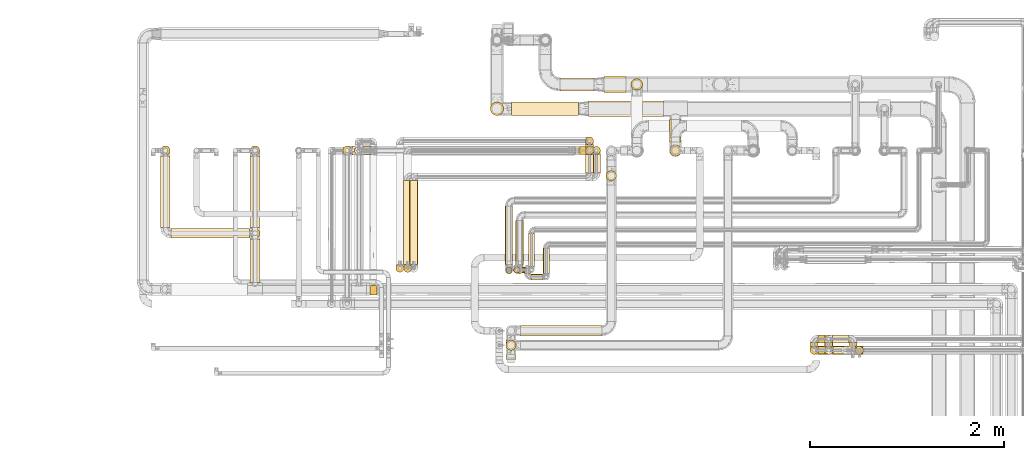
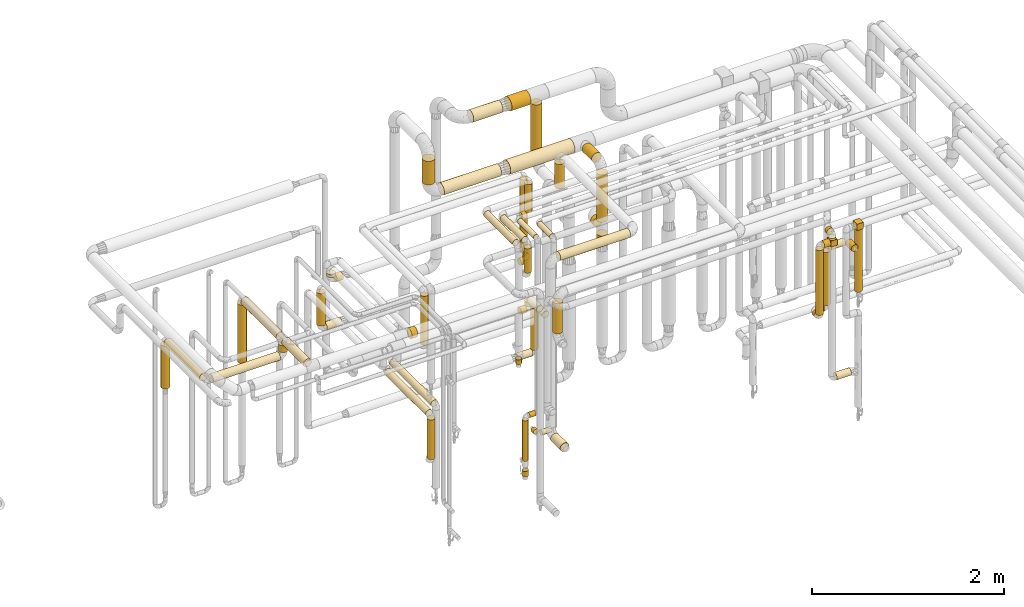
# One storey, part 17 of 827: 65 coverings.
"""IFC2X3 building model written with IfcOpenShell, lengths in millimetres."""

from ifc_helpers import new_model, entity, si_unit, converted_unit, derived_unit, direction, frame, frame_2d, origin, origin_2d_with_axis, place, context, subcontext, project, spatial, polyline, circle_curve, parameter, trimmed, segment, composite_curve, rectangle, circle, outline, extrude, element, save


model = new_model("IFC2X3")

# Units and contexts
model_context = context("Model", 3, precision=0.01, world=origin(), true_north=direction((6.12303176911189e-17, 1.0)))
body_context = subcontext(model_context, "Body", "Model", "MODEL_VIEW")
ifc_project = project(units=[si_unit("LENGTHUNIT", "METRE", prefix="MILLI"), si_unit("AREAUNIT", "SQUARE_METRE"), si_unit("VOLUMEUNIT", "CUBIC_METRE"), converted_unit("PLANEANGLEUNIT", "DEGREE", entity("IfcRatioMeasure", 0.0174532925199433), si_unit("PLANEANGLEUNIT", "RADIAN"), dimensions=[0, 0, 0, 0, 0, 0, 0]), si_unit("MASSUNIT", "GRAM", prefix="KILO"), derived_unit("MASSDENSITYUNIT", [(si_unit("MASSUNIT", "GRAM", prefix="KILO"), 1), (si_unit("LENGTHUNIT", "METRE"), -3)]), derived_unit("MOMENTOFINERTIAUNIT", [(si_unit("LENGTHUNIT", "METRE"), 4)]), si_unit("TIMEUNIT", "SECOND"), si_unit("FREQUENCYUNIT", "HERTZ"), si_unit("THERMODYNAMICTEMPERATUREUNIT", "DEGREE_CELSIUS"), derived_unit("THERMALTRANSMITTANCEUNIT", [(si_unit("MASSUNIT", "GRAM", prefix="KILO"), 1), (si_unit("THERMODYNAMICTEMPERATUREUNIT", "KELVIN"), -1), (si_unit("TIMEUNIT", "SECOND"), -3)]), derived_unit("VOLUMETRICFLOWRATEUNIT", [(si_unit("LENGTHUNIT", "METRE"), 3), (si_unit("TIMEUNIT", "SECOND"), -1)]), derived_unit("MASSFLOWRATEUNIT", [(si_unit("MASSUNIT", "GRAM", prefix="KILO"), 1), (si_unit("TIMEUNIT", "SECOND"), -1)]), derived_unit("ROTATIONALFREQUENCYUNIT", [(si_unit("TIMEUNIT", "SECOND"), -1)]), si_unit("ELECTRICCURRENTUNIT", "AMPERE"), si_unit("ELECTRICVOLTAGEUNIT", "VOLT"), si_unit("POWERUNIT", "WATT"), si_unit("FORCEUNIT", "NEWTON", prefix="KILO"), si_unit("ILLUMINANCEUNIT", "LUX"), si_unit("LUMINOUSFLUXUNIT", "LUMEN"), si_unit("LUMINOUSINTENSITYUNIT", "CANDELA"), derived_unit("USERDEFINED", [(si_unit("MASSUNIT", "GRAM", prefix="KILO"), -1), (si_unit("LENGTHUNIT", "METRE"), -2), (si_unit("TIMEUNIT", "SECOND"), 3), (si_unit("LUMINOUSFLUXUNIT", "LUMEN"), 1)]), derived_unit("LINEARVELOCITYUNIT", [(si_unit("LENGTHUNIT", "METRE"), 1), (si_unit("TIMEUNIT", "SECOND"), -1)]), si_unit("PRESSUREUNIT", "PASCAL"), derived_unit("USERDEFINED", [(si_unit("LENGTHUNIT", "METRE"), -2), (si_unit("MASSUNIT", "GRAM", prefix="KILO"), 1), (si_unit("TIMEUNIT", "SECOND"), -2)]), derived_unit("LINEARFORCEUNIT", [(si_unit("MASSUNIT", "GRAM", prefix="KILO"), 1), (si_unit("LENGTHUNIT", "METRE"), 1), (si_unit("TIMEUNIT", "SECOND"), -2), (si_unit("LENGTHUNIT", "METRE"), -1)]), derived_unit("PLANARFORCEUNIT", [(si_unit("MASSUNIT", "GRAM", prefix="KILO"), 1), (si_unit("LENGTHUNIT", "METRE"), 1), (si_unit("TIMEUNIT", "SECOND"), -2), (si_unit("LENGTHUNIT", "METRE"), -2)])], contexts=[model_context])

# Site, building, storey
site_placement = place(None, origin())
site = spatial("IfcSite", under=ifc_project, at=site_placement, CompositionType="ELEMENT")
building_placement = place(site_placement, origin())
building = spatial("IfcBuilding", under=site, at=building_placement, CompositionType="ELEMENT")
storey_placement = place(building_placement, frame((0.0, 0.0, 28200.0)))
storey = spatial("IfcBuildingStorey", under=building, at=storey_placement, Name="08", CompositionType="ELEMENT", Elevation=28200.0)

# Coverings
covering_1_placement = place(storey_placement, frame((53070.46, 17449.4, 1898.17)))
element("IfcCovering", 1, at=covering_1_placement, inside=storey, Name=":ADSK_", ObjectType=":ADSK_", PredefinedType="INSULATION", context=body_context, shape_type="SweptSolid", body=[
    extrude(circle(Radius=49.0, at=origin_2d_with_axis()), frame((50.6, 50.6, 0.0), z_axis=(0.0, 0.0, 1.0), x_axis=(-1.0, 0.0, 0.0)), (0.0, 0.0, 1.0), 743.078196918212),
])
covering_2_placement = place(storey_placement, frame((53070.46, 16139.31, 2648.82)))
element("IfcCovering", 2, at=covering_2_placement, inside=storey, Name=":ADSK_", ObjectType=":ADSK_", PredefinedType="INSULATION", context=body_context, shape_type="SweptSolid", body=[
    extrude(circle(Radius=49.0, at=origin_2d_with_axis()), frame((50.6, 452.08, 50.6), z_axis=(0.0, -0.999999057686603, 0.00137281677840633), x_axis=(1.0, 0.0, 0.0)), (0.0, 0.0, 1.0), 452.00943964707),
])
covering_3_placement = place(storey_placement, frame((52147.68, 17449.4, 1898.17)))
element("IfcCovering", 3, at=covering_3_placement, inside=storey, Name=":ADSK_", ObjectType=":ADSK_", PredefinedType="INSULATION", context=body_context, shape_type="SweptSolid", body=[
    extrude(circle(Radius=49.0, at=origin_2d_with_axis()), frame((50.6, 50.6, 0.0), z_axis=(0.0, 0.0, 1.0), x_axis=(-1.0, 0.0, 0.0)), (0.0, 0.0, 1.0), 543.000000000011),
])
covering_4_placement = place(storey_placement, frame((52147.68, 16705.39, 2447.57)))
element("IfcCovering", 4, at=covering_4_placement, inside=storey, Name=":ADSK_", ObjectType=":ADSK_", PredefinedType="INSULATION", context=body_context, shape_type="SweptSolid", body=[
    extrude(circle(Radius=49.0, at=origin_2d_with_axis()), frame((50.6, 0.0, 50.6), z_axis=(0.0, 1.0, 0.0), x_axis=(1.0, 0.0, 0.0)), (0.0, 0.0, 1.0), 737.613736356019),
])
covering_5_placement = place(storey_placement, frame((52255.28, 16597.79, 2447.57)))
element("IfcCovering", 5, at=covering_5_placement, inside=storey, Name=":ADSK_", ObjectType=":ADSK_", PredefinedType="INSULATION", context=body_context, shape_type="SweptSolid", body=[
    extrude(circle(Radius=49.0, at=origin_2d_with_axis()), frame((0.0, 50.6, 50.6), z_axis=(1.0, 0.0, 0.0), x_axis=(0.0, 1.0, 0.0)), (0.0, 0.0, 1.0), 808.780981573714),
])
covering_6_placement = place(storey_placement, frame((53070.46, 16597.71, 2555.14)))
element("IfcCovering", 6, at=covering_6_placement, inside=storey, Name=":ADSK_", ObjectType=":ADSK_", PredefinedType="INSULATION", context=body_context, shape_type="SweptSolid", body=[
    extrude(circle(Radius=49.0, at=origin_2d_with_axis()), frame((50.6, 50.64, 0.03), z_axis=(0.0, -0.000542908855839149, 0.999999852624976), x_axis=(0.0, -0.999999852624976, -0.000542908855839149)), (0.0, 0.0, 1.0), 87.1320315967125),
])
covering_7_placement = place(storey_placement, frame((53070.46, 16705.32, 2647.65)))
element("IfcCovering", 7, at=covering_7_placement, inside=storey, Name=":ADSK_", ObjectType=":ADSK_", PredefinedType="INSULATION", context=body_context, shape_type="SweptSolid", body=[
    extrude(circle(Radius=49.0, at=origin_2d_with_axis()), frame((50.6, 0.07, 51.61), z_axis=(0.0, 0.999999057686602, -0.00137281677839978), x_axis=(1.0, 0.0, 0.0)), (0.0, 0.0, 1.0), 737.692684756272),
])
covering_8_placement = place(storey_placement, frame((57387.04, 17586.0, 2039.15)))
element("IfcCovering", 8, at=covering_8_placement, inside=storey, Name=":ADSK_", ObjectType=":ADSK_", PredefinedType="INSULATION", context=body_context, shape_type="SweptSolid", body=[
    extrude(circle(Radius=59.25, at=origin_2d_with_axis()), frame((60.85, 0.0, 60.85), z_axis=(0.0, 1.0, 0.0), x_axis=(1.0, 0.0, 0.0)), (0.0, 0.0, 1.0), 55.0961141089978),
])
covering_9_placement = place(storey_placement, frame((57387.04, 17614.0, 2839.12)))
element("IfcCovering", 9, at=covering_9_placement, inside=storey, Name=":ADSK_", ObjectType=":ADSK_", PredefinedType="INSULATION", context=body_context, shape_type="SweptSolid", body=[
    extrude(circle(Radius=59.25, at=origin_2d_with_axis()), frame((60.85, 0.0, 60.85), z_axis=(0.0, 1.0, 0.0), x_axis=(1.0, 0.0, 0.0)), (0.0, 0.0, 1.0), 205.096097794299),
])
covering_10_placement = place(storey_placement, frame((57387.04, 17439.15, 1915.45)))
element("IfcCovering", 10, at=covering_10_placement, inside=storey, Name=":ADSK_", ObjectType=":ADSK_", PredefinedType="INSULATION", context=body_context, shape_type="SweptSolid", body=[
    extrude(circle(Radius=59.25, at=origin_2d_with_axis()), frame((60.85, 60.85, 0.0), z_axis=(0.0, 0.0, 1.0), x_axis=(-1.0, 0.0, 0.0)), (0.0, 0.0, 1.0), 98.5472224728106),
])
covering_11_placement = place(storey_placement, frame((57387.04, 17439.15, 2186.0)))
element("IfcCovering", 11, at=covering_11_placement, inside=storey, Name=":ADSK_", ObjectType=":ADSK_", PredefinedType="INSULATION", context=body_context, shape_type="SweptSolid", body=[
    extrude(circle(Radius=59.25, at=origin_2d_with_axis()), frame((60.85, 60.85, 0.0), z_axis=(0.0, 0.0, 1.0), x_axis=(-1.0, 0.0, 0.0)), (0.0, 0.0, 1.0), 600.000000000011),
])
covering_12_placement = place(storey_placement, frame((59297.12, 15400.86, 1868.01)))
element("IfcCovering", 12, at=covering_12_placement, inside=storey, Name=":ADSK_", ObjectType=":ADSK_", PredefinedType="INSULATION", context=body_context, shape_type="SweptSolid", body=[
    extrude(circle(Radius=41.75, at=origin_2d_with_axis()), frame((43.35, 43.35, 0.0), z_axis=(0.0, 0.0, 1.0), x_axis=(0.0, -1.0, 0.0)), (0.0, 0.0, 1.0), 793.987023342036),
])
covering_13_placement = place(storey_placement, frame((59302.46, 15402.36, 2662.0)))
element("IfcCovering", 13, at=covering_13_placement, inside=storey, Name=":ADSK_", ObjectType=":ADSK_", PredefinedType="INSULATION", context=body_context, shape_type="SweptSolid", body=[
    extrude(rectangle(XDim=75.9999999999914, YDim=83.7000000000026, at=origin_2d_with_axis()), frame((38.0, 41.85, 0.0)), (0.0, 0.0, 1.0), 79.8499999999992),
])
covering_14_placement = place(storey_placement, frame((58981.79, 15482.21, 2656.65)))
element("IfcCovering", 14, at=covering_14_placement, inside=storey, Name=":ADSK_", ObjectType=":ADSK_", PredefinedType="INSULATION", context=body_context, shape_type="SweptSolid", body=[
    extrude(circle(Radius=41.75, at=origin_2d_with_axis()), frame((43.35, 0.0, 43.35), z_axis=(0.0, 1.0, 0.0), x_axis=(1.0, 0.0, 0.0)), (0.0, 0.0, 1.0), 40.3142874709578),
])
covering_15_placement = place(storey_placement, frame((59063.14, 15400.86, 827.17)))
element("IfcCovering", 15, at=covering_15_placement, inside=storey, Name=":ADSK_", ObjectType=":ADSK_", PredefinedType="INSULATION", context=body_context, shape_type="SweptSolid", body=[
    extrude(circle(Radius=41.75, at=origin_2d_with_axis()), frame((0.0, 43.35, 43.35), z_axis=(1.0, 0.0, 0.0), x_axis=(0.0, 1.0, 0.0)), (0.0, 0.0, 1.0), 172.217361032213),
])
covering_16_placement = place(storey_placement, frame((58911.89, 15400.86, 2556.65)))
element("IfcCovering", 16, at=covering_16_placement, inside=storey, Name=":ADSK_", ObjectType=":ADSK_", PredefinedType="INSULATION", context=body_context, shape_type="SweptSolid", body=[
    extrude(circle(Radius=41.75, at=origin_2d_with_axis()), frame((0.0, 43.35, 43.35), z_axis=(1.0, 0.0, 0.0), x_axis=(0.0, -1.0, 0.0)), (0.0, 0.0, 1.0), 75.2500000000219),
])
covering_17_placement = place(storey_placement, frame((58987.14, 15402.36, 2562.0)))
element("IfcCovering", 17, at=covering_17_placement, inside=storey, Name=":ADSK_", ObjectType=":ADSK_", PredefinedType="INSULATION", context=body_context, shape_type="SweptSolid", body=[
    extrude(rectangle(XDim=79.8500000000035, YDim=83.7000000000026, at=origin_2d_with_axis()), frame((39.93, 41.85, 0.0)), (0.0, 0.0, 1.0), 75.9999999999957),
])
covering_18_placement = place(storey_placement, frame((58981.79, 15400.86, 2638.0)))
element("IfcCovering", 18, at=covering_18_placement, inside=storey, Name=":ADSK_", ObjectType=":ADSK_", PredefinedType="INSULATION", context=body_context, shape_type="SweptSolid", body=[
    extrude(circle(Radius=41.75, at=origin_2d_with_axis()), frame((43.35, 43.35, 0.0)), (0.0, 0.0, 1.0), 24.0000000000075),
])
covering_19_placement = place(storey_placement, frame((58830.54, 15400.86, 1738.53)))
element("IfcCovering", 19, at=covering_19_placement, inside=storey, Name=":ADSK_", ObjectType=":ADSK_", PredefinedType="INSULATION", context=body_context, shape_type="SweptSolid", body=[
    extrude(circle(Radius=41.75, at=origin_2d_with_axis()), frame((43.35, 43.35, 0.0)), (0.0, 0.0, 1.0), 823.470090868733),
])
covering_20_placement = place(storey_placement, frame((58830.54, 15482.21, 1657.18)))
element("IfcCovering", 20, at=covering_20_placement, inside=storey, Name=":ADSK_", ObjectType=":ADSK_", PredefinedType="INSULATION", context=body_context, shape_type="SweptSolid", body=[
    extrude(circle(Radius=41.75, at=origin_2d_with_axis()), frame((43.35, 0.0, 43.35), z_axis=(0.0, 1.0, 0.0), x_axis=(-1.0, 0.0, 0.0)), (0.0, 0.0, 1.0), 40.2592236656059),
])
covering_21_placement = place(storey_placement, frame((58911.89, 15517.12, 1657.18)))
element("IfcCovering", 21, at=covering_21_placement, inside=storey, Name=":ADSK_", ObjectType=":ADSK_", PredefinedType="INSULATION", context=body_context, shape_type="SweptSolid", body=[
    extrude(circle(Radius=41.75, at=origin_2d_with_axis()), frame((0.0, 43.35, 43.35), z_axis=(1.0, 0.0, 0.0), x_axis=(0.0, 1.0, 0.0)), (0.0, 0.0, 1.0), 74.0000000000178),
])
covering_22_placement = place(storey_placement, frame((58980.54, 15517.12, 1738.53)))
element("IfcCovering", 22, at=covering_22_placement, inside=storey, Name=":ADSK_", ObjectType=":ADSK_", PredefinedType="INSULATION", context=body_context, shape_type="SweptSolid", body=[
    extrude(circle(Radius=41.75, at=origin_2d_with_axis()), frame((43.35, 43.35, 0.0), z_axis=(0.0, 0.0, 1.0), x_axis=(0.0, 1.0, 0.0)), (0.0, 0.0, 1.0), 674.000039895076),
])
covering_23_placement = place(storey_placement, frame((59061.89, 15517.18, 2407.18)))
element("IfcCovering", 23, at=covering_23_placement, inside=storey, Name=":ADSK_", ObjectType=":ADSK_", PredefinedType="INSULATION", context=body_context, shape_type="SweptSolid", body=[
    extrude(circle(Radius=41.75, at=origin_2d_with_axis()), frame((0.0, 43.35, 43.35), z_axis=(1.0, 0.0, 0.0), x_axis=(0.0, 1.0, 0.0)), (0.0, 0.0, 1.0), 173.467361032217),
])
covering_24_placement = place(storey_placement, frame((59230.01, 15402.52, 2407.18)))
element("IfcCovering", 24, at=covering_24_placement, inside=storey, Name=":ADSK_", ObjectType=":ADSK_", PredefinedType="INSULATION", context=body_context, shape_type="SweptSolid", body=[
    extrude(circle(Radius=41.75, at=origin_2d_with_axis()), frame((43.35, 0.0, 43.35), z_axis=(0.0, 1.0, 0.0), x_axis=(1.0, 0.0, 0.0)), (0.0, 0.0, 1.0), 119.99999999999),
])
covering_25_placement = place(storey_placement, frame((56551.05, 17847.0, 2816.87)))
element("IfcCovering", 25, at=covering_25_placement, inside=storey, Name=":ADSK_", ObjectType=":ADSK_", PredefinedType="INSULATION", context=body_context, shape_type="SweptSolid", body=[
    extrude(circle(Radius=81.5, at=origin_2d_with_axis()), frame((0.0, 83.1, 83.1), z_axis=(1.0, 0.0, 0.0), x_axis=(0.0, -1.0, 0.0)), (0.0, 0.0, 1.0), 772.836562103827),
])
covering_26_placement = place(storey_placement, frame((55761.05, 17859.5, 2829.37)))
element("IfcCovering", 26, at=covering_26_placement, inside=storey, Name=":ADSK_", ObjectType=":ADSK_", PredefinedType="INSULATION", context=body_context, shape_type="SweptSolid", body=[
    extrude(circle(Radius=69.0, at=origin_2d_with_axis()), frame((0.0, 70.6, 70.6), z_axis=(1.0, 0.0, 0.0), x_axis=(0.0, -1.0, 0.0)), (0.0, 0.0, 1.0), 690.000000000068),
])
covering_27_placement = place(storey_placement, frame((55540.45, 17859.5, 3049.96)))
element("IfcCovering", 27, at=covering_27_placement, inside=storey, Name=":ADSK_", ObjectType=":ADSK_", PredefinedType="INSULATION", context=body_context, shape_type="SweptSolid", body=[
    extrude(circle(Radius=69.0, at=origin_2d_with_axis()), frame((70.6, 70.6, 0.0), z_axis=(0.0, 0.0, 1.0), x_axis=(0.0, -1.0, 0.0)), (0.0, 0.0, 1.0), 299.782089013241),
])
covering_28_placement = place(storey_placement, frame((56519.88, 17456.65, 2605.5)))
element("IfcCovering", 28, at=covering_28_placement, inside=storey, Name=":ADSK_", ObjectType=":ADSK_", PredefinedType="INSULATION", context=body_context, shape_type="SweptSolid", body=[
    extrude(circle(Radius=41.75, at=origin_2d_with_axis()), frame((43.35, 43.35, 0.0), z_axis=(0.0, 0.0, 1.0), x_axis=(0.0, -1.0, 0.0)), (0.0, 0.0, 1.0), 356.499999999793),
])
covering_29_placement = place(storey_placement, frame((56472.19, 17456.65, 2524.15)))
element("IfcCovering", 29, at=covering_29_placement, inside=storey, Name=":ADSK_", ObjectType=":ADSK_", PredefinedType="INSULATION", context=body_context, shape_type="SweptSolid", body=[
    extrude(circle(Radius=41.75, at=origin_2d_with_axis()), frame((0.0, 43.35, 43.35), z_axis=(1.0, 0.0, 0.0), x_axis=(0.0, -1.0, 0.0)), (0.0, 0.0, 1.0), 53.0388803778343),
])
covering_30_placement = place(storey_placement, frame((54142.04, 17452.25, 2615.5)))
element("IfcCovering", 30, at=covering_30_placement, inside=storey, Name=":ADSK_", ObjectType=":ADSK_", PredefinedType="INSULATION", context=body_context, shape_type="SweptSolid", body=[
    extrude(circle(Radius=46.15, at=origin_2d_with_axis()), frame((47.75, 47.75, 0.0), z_axis=(0.0, 0.0, 1.0), x_axis=(-1.0, 0.0, 0.0)), (0.0, 0.0, 1.0), 36.4999999999354),
])
covering_31_placement = place(storey_placement, frame((54237.79, 17452.25, 2519.75)))
element("IfcCovering", 31, at=covering_31_placement, inside=storey, Name=":ADSK_", ObjectType=":ADSK_", PredefinedType="INSULATION", context=body_context, shape_type="SweptSolid", body=[
    extrude(circle(Radius=46.15, at=origin_2d_with_axis()), frame((0.0, 47.75, 47.75), z_axis=(1.0, 0.0, 0.0), x_axis=(0.0, 1.0, 0.0)), (0.0, 0.0, 1.0), 77.0000000000172),
])
covering_32_placement = place(storey_placement, frame((54568.84, 16245.22, 2338.09)))
element("IfcCovering", 32, at=covering_32_placement, inside=storey, Name=":ADSK_", ObjectType=":ADSK_", PredefinedType="INSULATION", context=body_context, shape_type="SweptSolid", body=[
    extrude(circle(Radius=41.75, at=origin_2d_with_axis()), frame((43.35, 43.35, 0.0)), (0.0, 0.0, 1.0), 624.000000000014),
])
covering_33_placement = place(storey_placement, frame((56519.88, 17555.47, 2030.5)))
element("IfcCovering", 33, at=covering_33_placement, inside=storey, Name=":ADSK_", ObjectType=":ADSK_", PredefinedType="INSULATION", context=body_context, shape_type="SweptSolid", body=[
    extrude(circle(Radius=41.75, at=origin_2d_with_axis()), frame((43.35, 43.35, 0.0)), (0.0, 0.0, 1.0), 931.586150798507),
])
covering_34_placement = place(storey_placement, frame((56519.88, 17538.0, 1949.15)))
element("IfcCovering", 34, at=covering_34_placement, inside=storey, Name=":ADSK_", ObjectType=":ADSK_", PredefinedType="INSULATION", context=body_context, shape_type="SweptSolid", body=[
    extrude(circle(Radius=41.75, at=origin_2d_with_axis()), frame((43.35, 0.0, 43.35), z_axis=(0.0, 1.0, 0.0), x_axis=(1.0, 0.0, 0.0)), (0.0, 0.0, 1.0), 22.8207544577575),
])
covering_35_placement = place(storey_placement, frame((56454.69, 17456.65, 1949.15)))
element("IfcCovering", 35, at=covering_35_placement, inside=storey, Name=":ADSK_", ObjectType=":ADSK_", PredefinedType="INSULATION", context=body_context, shape_type="SweptSolid", body=[
    extrude(circle(Radius=41.75, at=origin_2d_with_axis()), frame((0.0, 43.35, 43.35), z_axis=(1.0, 0.0, 0.0), x_axis=(0.0, -1.0, 0.0)), (0.0, 0.0, 1.0), 70.5388803777957),
])
covering_36_placement = place(storey_placement, frame((54022.04, 17452.25, 2040.5)))
element("IfcCovering", 36, at=covering_36_placement, inside=storey, Name=":ADSK_", ObjectType=":ADSK_", PredefinedType="INSULATION", context=body_context, shape_type="SweptSolid", body=[
    extrude(circle(Radius=46.15, at=origin_2d_with_axis()), frame((47.75, 47.75, 0.0), z_axis=(0.0, 0.0, 1.0), x_axis=(-1.0, 0.0, 0.0)), (0.0, 0.0, 1.0), 411.500000000015),
])
covering_37_placement = place(storey_placement, frame((54117.79, 17452.25, 1944.75)))
element("IfcCovering", 37, at=covering_37_placement, inside=storey, Name=":ADSK_", ObjectType=":ADSK_", PredefinedType="INSULATION", context=body_context, shape_type="SweptSolid", body=[
    extrude(circle(Radius=46.15, at=origin_2d_with_axis()), frame((0.0, 47.75, 47.75), z_axis=(1.0, 0.0, 0.0), x_axis=(0.0, 1.0, 0.0)), (0.0, 0.0, 1.0), 182.000000000011),
])
covering_38_placement = place(storey_placement, frame((54648.84, 16326.56, 1356.65)))
element("IfcCovering", 38, at=covering_38_placement, inside=storey, Name=":ADSK_", ObjectType=":ADSK_", PredefinedType="INSULATION", context=body_context, shape_type="SweptSolid", body=[
    extrude(circle(Radius=41.75, at=origin_2d_with_axis()), frame((43.35, 0.0, 43.35), z_axis=(0.0, 1.0, 0.0), x_axis=(1.0, 0.0, 0.0)), (0.0, 0.0, 1.0), 864.000000000016),
])
covering_39_placement = place(storey_placement, frame((54648.84, 16245.22, 858.0)))
element("IfcCovering", 39, at=covering_39_placement, inside=storey, Name=":ADSK_", ObjectType=":ADSK_", PredefinedType="INSULATION", context=body_context, shape_type="SweptSolid", body=[
    extrude(circle(Radius=41.75, at=origin_2d_with_axis()), frame((43.35, 43.35, 0.0), z_axis=(0.0, 0.0, 1.0), x_axis=(-1.0, 0.0, 0.0)), (0.0, 0.0, 1.0), 504.000000000015),
])
covering_40_placement = place(storey_placement, frame((56589.88, 17266.56, 1356.65)))
element("IfcCovering", 40, at=covering_40_placement, inside=storey, Name=":ADSK_", ObjectType=":ADSK_", PredefinedType="INSULATION", context=body_context, shape_type="SweptSolid", body=[
    extrude(circle(Radius=41.75, at=origin_2d_with_axis()), frame((43.35, 0.0, 43.35), z_axis=(0.0, 1.0, 0.0), x_axis=(-1.0, 0.0, 0.0)), (0.0, 0.0, 1.0), 195.438135542264),
])
covering_41_placement = place(storey_placement, frame((56589.88, 17456.65, 830.5)))
element("IfcCovering", 41, at=covering_41_placement, inside=storey, Name=":ADSK_", ObjectType=":ADSK_", PredefinedType="INSULATION", context=body_context, shape_type="SweptSolid", body=[
    extrude(circle(Radius=41.75, at=origin_2d_with_axis()), frame((43.35, 43.35, 0.0), z_axis=(0.0, 0.0, 1.0), x_axis=(-1.0, 0.0, 0.0)), (0.0, 0.0, 1.0), 531.500000000009),
])
covering_42_placement = place(storey_placement, frame((56418.23, 17456.65, 749.15)))
element("IfcCovering", 42, at=covering_42_placement, inside=storey, Name=":ADSK_", ObjectType=":ADSK_", PredefinedType="INSULATION", context=body_context, shape_type="SweptSolid", body=[
    extrude(circle(Radius=41.75, at=origin_2d_with_axis()), frame((0.0, 43.35, 43.35), z_axis=(1.0, 0.0, 0.0), x_axis=(0.0, -1.0, 0.0)), (0.0, 0.0, 1.0), 177.00000000002),
])
covering_43_placement = place(storey_placement, frame((56520.88, 17266.56, 1456.65)))
element("IfcCovering", 43, at=covering_43_placement, inside=storey, Name=":ADSK_", ObjectType=":ADSK_", PredefinedType="INSULATION", context=body_context, shape_type="SweptSolid", body=[
    extrude(circle(Radius=41.75, at=origin_2d_with_axis()), frame((43.35, 0.0, 43.35), z_axis=(0.0, 1.0, 0.0), x_axis=(-1.0, 0.0, 0.0)), (0.0, 0.0, 1.0), 195.438135542264),
])
covering_44_placement = place(storey_placement, frame((54710.88, 16326.56, 1456.65)))
element("IfcCovering", 44, at=covering_44_placement, inside=storey, Name=":ADSK_", ObjectType=":ADSK_", PredefinedType="INSULATION", context=body_context, shape_type="SweptSolid", body=[
    extrude(circle(Radius=41.75, at=origin_2d_with_axis()), frame((43.35, 0.0, 43.35), z_axis=(0.0, 1.0, 0.0), x_axis=(1.0, 0.0, 0.0)), (0.0, 0.0, 1.0), 864.000000000014),
])
covering_45_placement = place(storey_placement, frame((56454.23, 17456.65, 1326.65)))
element("IfcCovering", 45, at=covering_45_placement, inside=storey, Name=":ADSK_", ObjectType=":ADSK_", PredefinedType="INSULATION", context=body_context, shape_type="SweptSolid", body=[
    extrude(circle(Radius=41.75, at=origin_2d_with_axis()), frame((0.0, 43.35, 43.35), z_axis=(1.0, 0.0, 0.0), x_axis=(0.0, -1.0, 0.0)), (0.0, 0.0, 1.0), 72.0000000000269),
])
covering_46_placement = place(storey_placement, frame((56520.88, 17456.65, 1408.0)))
element("IfcCovering", 46, at=covering_46_placement, inside=storey, Name=":ADSK_", ObjectType=":ADSK_", PredefinedType="INSULATION", context=body_context, shape_type="SweptSolid", body=[
    extrude(circle(Radius=41.75, at=origin_2d_with_axis()), frame((43.35, 43.35, 0.0), z_axis=(0.0, 0.0, 1.0), x_axis=(0.0, 1.0, 0.0)), (0.0, 0.0, 1.0), 54.0000000000224),
])
covering_47_placement = place(storey_placement, frame((55802.54, 16327.44, 3159.4)))
element("IfcCovering", 47, at=covering_47_placement, inside=storey, Name=":ADSK_", ObjectType=":ADSK_", PredefinedType="INSULATION", context=body_context, shape_type="SweptSolid", body=[
    extrude(circle(Radius=39.0, at=origin_2d_with_axis()), frame((40.6, 0.0, 40.6), z_axis=(0.0, 1.0, 0.0), x_axis=(1.0, 0.0, 0.0)), (0.0, 0.0, 1.0), 453.499999999986),
])
covering_48_placement = place(storey_placement, frame((55802.54, 16229.84, 2832.0)))
element("IfcCovering", 48, at=covering_48_placement, inside=storey, Name=":ADSK_", ObjectType=":ADSK_", PredefinedType="INSULATION", context=body_context, shape_type="SweptSolid", body=[
    extrude(circle(Radius=39.0, at=origin_2d_with_axis()), frame((40.6, 40.6, 0.0), z_axis=(0.0, 0.0, 1.0), x_axis=(-1.0, 0.0, 0.0)), (0.0, 0.0, 1.0), 310.999999999973),
])
covering_49_placement = place(storey_placement, frame((56084.79, 16235.94, 3166.65)))
element("IfcCovering", 49, at=covering_49_placement, inside=storey, Name=":ADSK_", ObjectType=":ADSK_", PredefinedType="INSULATION", context=body_context, shape_type="SweptSolid", body=[
    extrude(circle(Radius=31.75, at=origin_2d_with_axis()), frame((33.35, 0.0, 33.35), z_axis=(0.0, 1.0, 0.0), x_axis=(1.0, 0.0, 0.0)), (0.0, 0.0, 1.0), 261.759412695868),
])
covering_50_placement = place(storey_placement, frame((55961.13, 16164.59, 751.4)))
element("IfcCovering", 50, at=covering_50_placement, inside=storey, Name=":ADSK_", ObjectType=":ADSK_", PredefinedType="INSULATION", context=body_context, shape_type="SweptSolid", body=[
    extrude(circle(Radius=31.75, at=origin_2d_with_axis()), frame((0.0, 33.35, 33.35), z_axis=(1.0, 0.0, 0.0), x_axis=(0.0, -1.0, 0.0)), (0.0, 0.0, 1.0), 119.000000000016),
])
covering_51_placement = place(storey_placement, frame((55889.79, 16235.94, 751.4)))
element("IfcCovering", 51, at=covering_51_placement, inside=storey, Name=":ADSK_", ObjectType=":ADSK_", PredefinedType="INSULATION", context=body_context, shape_type="SweptSolid", body=[
    extrude(circle(Radius=31.75, at=origin_2d_with_axis()), frame((33.35, 0.0, 33.35), z_axis=(0.0, 1.0, 0.0), x_axis=(-1.0, 0.0, 0.0)), (0.0, 0.0, 1.0), 49.9999999999995),
])
covering_52_placement = place(storey_placement, frame((56711.05, 18097.0, 3416.65)))
element("IfcCovering", 52, at=covering_52_placement, inside=storey, Name=":ADSK_", ObjectType=":ADSK_", PredefinedType="INSULATION", context=body_context, shape_type="SweptSolid", body=[
    extrude(circle(Radius=81.5, at=origin_2d_with_axis()), frame((0.0, 83.1, 83.1), z_axis=(1.0, 0.0, 0.0), x_axis=(0.0, -1.0, 0.0)), (0.0, 0.0, 1.0), 229.02119087204),
])
covering_53_placement = place(storey_placement, frame((56258.55, 18109.5, 3429.15)))
element("IfcCovering", 53, at=covering_53_placement, inside=storey, Name=":ADSK_", ObjectType=":ADSK_", PredefinedType="INSULATION", context=body_context, shape_type="SweptSolid", body=[
    extrude(circle(Radius=69.0, at=origin_2d_with_axis()), frame((0.0, 70.6, 70.6), z_axis=(1.0, 0.0, 0.0), x_axis=(0.0, -1.0, 0.0)), (0.0, 0.0, 1.0), 352.499999999972),
])
covering_54_placement = place(storey_placement, frame((56989.22, 18119.25, 2719.74)))
element("IfcCovering", 54, at=covering_54_placement, inside=storey, Name=":ADSK_", ObjectType=":ADSK_", PredefinedType="INSULATION", context=body_context, shape_type="SweptSolid", body=[
    extrude(circle(Radius=59.25, at=origin_2d_with_axis()), frame((60.85, 60.85, 0.0)), (0.0, 0.0, 1.0), 684.999999999996),
])
covering_55_placement = place(storey_placement, frame((55932.01, 16308.44, 3166.65)))
element("IfcCovering", 55, at=covering_55_placement, inside=storey, Name=":ADSK_", ObjectType=":ADSK_", PredefinedType="INSULATION", context=body_context, shape_type="SweptSolid", body=[
    extrude(circle(Radius=31.75, at=origin_2d_with_axis()), frame((33.35, 0.0, 33.35), z_axis=(0.0, 1.0, 0.0), x_axis=(1.0, 0.0, 0.0)), (0.0, 0.0, 1.0), 339.25941269584),
])
covering_56_placement = place(storey_placement, frame((55693.58, 16324.94, 3159.4)))
element("IfcCovering", 56, at=covering_56_placement, inside=storey, Name=":ADSK_", ObjectType=":ADSK_", PredefinedType="INSULATION", context=body_context, shape_type="SweptSolid", body=[
    extrude(circle(Radius=39.0, at=origin_2d_with_axis()), frame((40.6, 0.0, 40.6), z_axis=(0.0, 1.0, 0.0), x_axis=(1.0, 0.0, 0.0)), (0.0, 0.0, 1.0), 603.75941269586),
])
covering_57_placement = place(storey_placement, frame((55850.84, 15591.86, 3345.65)))
element("IfcCovering", 57, at=covering_57_placement, inside=storey, Name=":ADSK_", ObjectType=":ADSK_", PredefinedType="INSULATION", context=body_context, shape_type="SweptSolid", body=[
    extrude(circle(Radius=52.75, at=origin_2d_with_axis()), frame((0.0, 54.35, 54.35), z_axis=(1.0, 0.0, 0.0), x_axis=(0.0, -1.0, 0.0)), (0.0, 0.0, 1.0), 841.541968197392),
])
covering_58_placement = place(storey_placement, frame((55853.36, 16237.09, 966.65)))
element("IfcCovering", 58, at=covering_58_placement, inside=storey, Name=":ADSK_", ObjectType=":ADSK_", PredefinedType="INSULATION", context=body_context, shape_type="SweptSolid", body=[
    extrude(circle(Radius=31.75, at=origin_2d_with_axis()), frame((0.0, 33.35, 33.35), z_axis=(1.0, 0.0, 0.0), x_axis=(0.0, -1.0, 0.0)), (0.0, 0.0, 1.0), 74.0000000000178),
])
covering_59_placement = place(storey_placement, frame((55782.01, 16237.09, 446.5)))
element("IfcCovering", 59, at=covering_59_placement, inside=storey, Name=":ADSK_", ObjectType=":ADSK_", PredefinedType="INSULATION", context=body_context, shape_type="SweptSolid", body=[
    extrude(circle(Radius=31.75, at=origin_2d_with_axis()), frame((33.35, 33.35, 0.0), z_axis=(0.0, 0.0, 1.0), x_axis=(0.0, -1.0, 0.0)), (0.0, 0.0, 1.0), 515.500000000004),
])
covering_60_placement = place(storey_placement, frame((55701.5, 15351.2, 1130.65)))
element("IfcCovering", 60, at=covering_60_placement, inside=storey, Name=":ADSK_", ObjectType=":ADSK_", PredefinedType="INSULATION", context=body_context, shape_type="SweptSolid", body=[
    extrude(circle(Radius=52.75, at=origin_2d_with_axis()), frame((54.35, 0.0, 54.35), z_axis=(0.0, 1.0, 0.0), x_axis=(1.0, 0.0, 0.0)), (0.0, 0.0, 1.0), 200.000000000009),
])
covering_61_placement = place(storey_placement, frame((55701.5, 15441.86, 2570.0)))
element("IfcCovering", 61, at=covering_61_placement, inside=storey, Name=":ADSK_", ObjectType=":ADSK_", PredefinedType="INSULATION", context=body_context, shape_type="SweptSolid", body=[
    extrude(circle(Radius=52.75, at=origin_2d_with_axis()), frame((54.35, 54.35, 0.0), z_axis=(0.0, 0.0, 1.0), x_axis=(0.0, -1.0, 0.0)), (0.0, 0.0, 1.0), 384.999999999969),
])
covering_62_placement = place(storey_placement, frame((55778.76, 16233.84, 249.5)))
element("IfcCovering", 62, at=covering_62_placement, inside=storey, Name=":ADSK_", ObjectType=":ADSK_", PredefinedType="INSULATION", context=body_context, shape_type="SweptSolid", body=[
    extrude(circle(Radius=35.0, at=origin_2d_with_axis()), frame((36.6, 36.6, 0.0), z_axis=(0.0, 0.0, 1.0), x_axis=(0.0, -1.0, 0.0)), (0.0, 0.0, 1.0), 70.0000000000014),
])
covering_63_placement = place(storey_placement, frame((55700.08, 16233.84, 1704.16)))
element("IfcCovering", 63, at=covering_63_placement, inside=storey, Name=":ADSK_", ObjectType=":ADSK_", PredefinedType="INSULATION", context=body_context, shape_type="SweptSolid", body=[
    extrude(circle(Radius=32.5, at=origin_2d_with_axis()), frame((34.1, 34.1, 0.0), z_axis=(0.0, 0.0, 1.0), x_axis=(0.0, 1.0, 0.0)), (0.0, 0.0, 1.0), 61.0000000000035),
])
covering_64_placement = place(storey_placement, frame((56733.04, 17185.65, 2995.0)))
element("IfcCovering", 64, at=covering_64_placement, inside=storey, Name=":ADSK_", ObjectType=":ADSK_", PredefinedType="INSULATION", context=body_context, shape_type="SweptSolid", body=[
    extrude(circle(Radius=52.75, at=origin_2d_with_axis()), frame((54.35, 54.35, 0.0)), (0.0, 0.0, 1.0), 309.999999999999),
])
covering_65_placement = place(storey_placement, frame((54304.79, 16010.78, 2638.44)))
element("IfcCovering", 65, at=covering_65_placement, inside=storey, Name=":ADSK_", ObjectType=":ADSK_", PredefinedType="INSULATION", context=body_context, shape_type="SweptSolid", body=[
    extrude(outline(composite_curve([segment(trimmed(circle_curve(frame_2d((14.29, 0.0), x_axis=(1.0, 0.0)), 60.0), [parameter(0.0)], [parameter(90.0)], True, "PARAMETER"), True, "CONTINUOUS"), segment(trimmed(circle_curve(frame_2d((14.29, 0.0), x_axis=(1.0, 0.0)), 60.0), [parameter(90.0000000000003)], [parameter(131.810314895778)], True, "PARAMETER"), True, "CONTINUOUS"), segment(polyline([(-25.71, 44.72), (-25.71, 13.46)]), True, "CONTINUOUS"), segment(polyline([(-25.71, 13.46), (-25.71, -13.46)]), True, "CONTINUOUS"), segment(polyline([(-25.71, -13.46), (-25.71, -44.72)]), True, "CONTINUOUS"), segment(trimmed(circle_curve(frame_2d((14.29, 0.0), x_axis=(1.0, 0.0)), 60.0), [parameter(228.189685104222)], [parameter(270.0)], True, "PARAMETER"), True, "CONTINUOUS"), segment(trimmed(circle_curve(frame_2d((14.29, 0.0), x_axis=(1.0, 0.0)), 60.0), [parameter(270.0)], [parameter(0.0)], True, "PARAMETER"), True, "CONTINUOUS")], self_intersect=False)), frame((0.0, 75.88, 61.6), z_axis=(1.0, 0.0, 0.0), x_axis=(0.0, -1.0, 0.0)), (0.0, 0.0, 1.0), 69.9999999999928),
])

save(model, "model.ifc")
